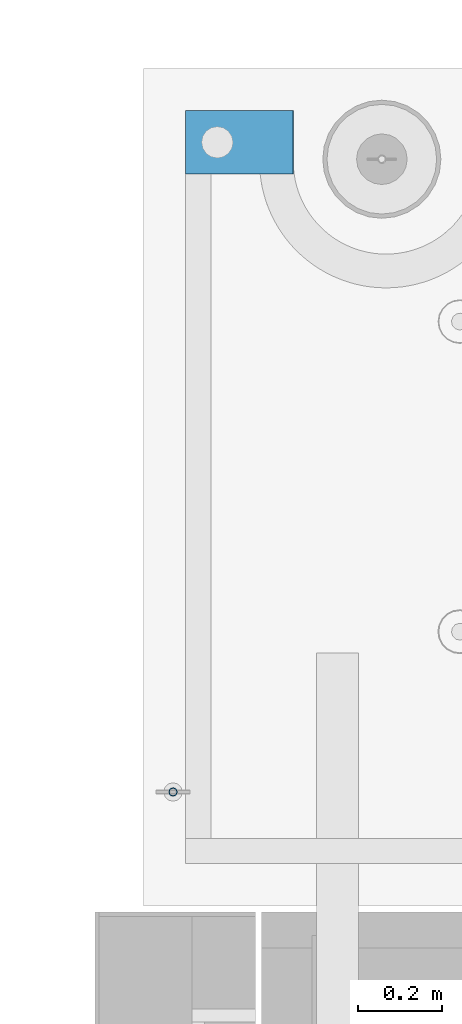
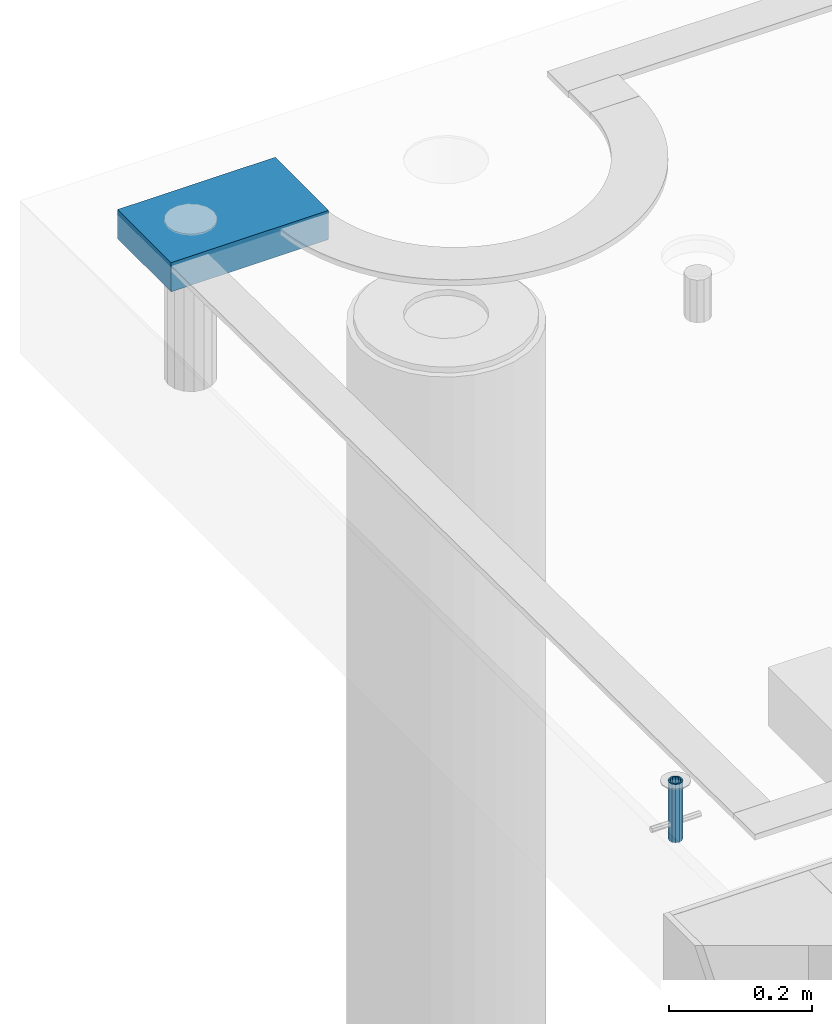
# One storey, part 154 of 349: 2 beams, 2 elements without a shape of their own.
"""IFC2X3 building model written with IfcOpenShell, lengths in millimetres."""

from ifc_helpers import new_model, si_unit, frame, origin_with_axes, place, context, subcontext, project, spatial, faceted_brep, material, type_object, element, aggregate, save


model = new_model("IFC2X3")

# Units and contexts
model_context = context("Model", 3, precision=1e-05, world=origin_with_axes())
body_context = subcontext(model_context, "Body", "Model", "MODEL_VIEW")
ifc_project = project(units=[si_unit("LENGTHUNIT", "METRE", prefix="MILLI"), si_unit("AREAUNIT", "SQUARE_METRE"), si_unit("VOLUMEUNIT", "CUBIC_METRE"), si_unit("MASSUNIT", "GRAM", prefix="KILO"), si_unit("TIMEUNIT", "SECOND"), si_unit("PLANEANGLEUNIT", "RADIAN"), si_unit("SOLIDANGLEUNIT", "STERADIAN"), si_unit("THERMODYNAMICTEMPERATUREUNIT", "DEGREE_CELSIUS"), si_unit("LUMINOUSINTENSITYUNIT", "LUMEN")], contexts=[model_context])

# Site, building, storey
site_placement = place(None, origin_with_axes())
site = spatial("IfcSite", under=ifc_project, at=site_placement, CompositionType="ELEMENT")
building_placement = place(site_placement, origin_with_axes())
building = spatial("IfcBuilding", under=site, at=building_placement, CompositionType="ELEMENT")
storey_placement = place(building_placement, origin_with_axes())
storey = spatial("IfcBuildingStorey", under=building, at=storey_placement, Name="4", CompositionType="ELEMENT", Elevation=0.0)

# Assemblies, beams
assembly_1_placement = place(storey_placement, origin_with_axes())
assembly_1 = element("IfcElementAssembly", 1, at=assembly_1_placement, inside=storey, AssemblyPlace="NOTDEFINED", PredefinedType="REINFORCEMENT_UNIT")
ifc_material_1 = material(Name="CONCRETE/Concrete_Undefined")
beam_type_1 = type_object("IfcBeamType", PredefinedType="NOTDEFINED")
beam_1_placement = place(assembly_1_placement, frame((7834.97852488622, 22709.9981419457, 93691.8130006467), z_axis=(-0.000811736999627788, 6.99999872856177e-09, 0.999999670541467), x_axis=(0.99999967050638, -8.37699998998561e-06, 0.000811736999618736)))
beam_1 = element("IfcBeam", 2, at=beam_1_placement, type_object=beam_type_1, material=ifc_material_1, context=body_context, shape_type="Brep", body=[
    faceted_brep([(0.0, 75.0, -25.0), (1.81898940354586e-12, 75.0, 25.0), (254.995831308013, 74.9999999999964, 24.9999999999709), (254.995831308012, 74.9999999999964, -25.0000000000146), (1.81898940354586e-12, -75.0000000000009, 25.0), (254.995831308014, -75.0000000000036, 24.9999999999854), (0.0, -75.0, -25.0), (254.995831308011, -75.0000000000036, -25.0000000000146)], [[[0, 1, 2, 3]], [[1, 4, 5, 2]], [[4, 6, 7, 5]], [[6, 0, 3, 7]], [[5, 7, 3, 2]], [[6, 4, 1, 0]]]),
])
assembly_2_placement = place(assembly_1_placement, origin_with_axes())
assembly_2 = element("IfcElementAssembly", 3, at=assembly_2_placement, Name="Steel Assembly", AssemblyPlace="NOTDEFINED", PredefinedType="RIGID_FRAME")
aggregate(assembly_1, [assembly_2, beam_1])
ifc_material_2 = material(Name="STEEL/1.4301")
beam_type_2 = type_object("IfcBeamType", PredefinedType="NOTDEFINED")
beam_2_placement = place(assembly_2_placement, frame((7804.99906039055, 21170.0168887753, 93730.9999983246), z_axis=(-1.43919999976435e-05, -0.999999999896435, 0.0), x_axis=(0.0, 0.0, -1.0)))
beam_2 = element("IfcBeam", 4, at=beam_2_placement, type_object=beam_type_2, material=ifc_material_2, context=body_context, shape_type="Brep", body=[
    faceted_brep([(0.0, -8.0, 0.0), (0.0, -6.92820323027263, 4.0), (100.000000000029, -6.92820323027263, 4.0), (100.000000000029, -7.99999999999636, 0.0), (0.0, -4.0, 6.92820323027627), (100.000000000029, -4.0, 6.92820323027536), (0.0, 0.0, 8.0), (100.000000000029, 3.63797880709171e-12, 8.0), (0.0, 4.0, 6.92820323027627), (100.000000000029, 4.0, 6.92820323027536), (0.0, 6.92820323027263, 4.0), (100.000000000029, 6.92820323027627, 3.99999999999909), (0.0, 8.0, 0.0), (100.000000000029, 8.0, 0.0), (0.0, 6.92820323027263, -4.0), (100.000000000029, 6.92820323027627, -4.00000000000091), (0.0, 4.0, -6.92820323027627), (100.000000000029, 4.00000000000364, -6.92820323027536), (0.0, 0.0, -8.0), (100.000000000029, 3.63797880709171e-12, -8.00000000000091), (0.0, -4.0, -6.92820323027627), (100.000000000029, -3.99999999999636, -6.92820323027627), (0.0, -6.92820323027263, -4.0), (100.000000000029, -6.92820323027263, -4.0), (0.0, -10.4999999999927, -1.45519152283669e-11), (0.0, -9.09326673972828, -5.25000000001455), (100.000000000262, -9.09326673972828, -5.25000000001455), (100.000000000262, -10.4999999999927, -1.45519152283669e-11), (0.0, -5.24999999998545, -9.09326673974283), (100.000000000262, -5.24999999998545, -9.09326673974283), (0.0, 7.27595761418343e-12, -10.5), (100.000000000262, 7.27595761418343e-12, -10.5), (0.0, 5.25000000001455, -9.09326673975738), (100.000000000262, 5.25000000001455, -9.09326673975738), (0.0, 9.09326673975011, -5.25000000001455), (100.000000000262, 9.09326673975011, -5.25000000001455), (0.0, 10.5000000000073, -1.45519152283669e-11), (100.000000000262, 10.5000000000073, -1.45519152283669e-11), (0.0, 9.09326673975011, 5.25), (100.000000000262, 9.09326673975011, 5.25), (0.0, 5.25000000000728, 9.09326673972828), (100.000000000262, 5.25000000000728, 9.09326673972828), (0.0, 1.45519152283669e-11, 10.4999999999854), (100.000000000262, 1.45519152283669e-11, 10.4999999999854), (0.0, -5.24999999999272, 9.09326673972828), (100.000000000262, -5.24999999999272, 9.09326673972828), (0.0, -9.09326673972828, 5.24999999998545), (100.000000000262, -9.09326673972828, 5.24999999998545)], [[[0, 1, 2, 3]], [[1, 4, 5, 2]], [[4, 6, 7, 5]], [[6, 8, 9, 7]], [[8, 10, 11, 9]], [[10, 12, 13, 11]], [[12, 14, 15, 13]], [[14, 16, 17, 15]], [[16, 18, 19, 17]], [[18, 20, 21, 19]], [[20, 22, 23, 21]], [[22, 0, 3, 23]], [[24, 25, 26, 27]], [[25, 28, 29, 26]], [[28, 30, 31, 29]], [[30, 32, 33, 31]], [[32, 34, 35, 33]], [[34, 36, 37, 35]], [[36, 38, 39, 37]], [[38, 40, 41, 39]], [[40, 42, 43, 41]], [[42, 44, 45, 43]], [[44, 46, 47, 45]], [[46, 24, 27, 47]], [[29, 31, 33, 35, 37, 39, 41, 43, 45, 47, 27, 26], [5, 7, 9, 11, 13, 15, 17, 19, 21, 23, 3, 2]], [[46, 44, 42, 40, 38, 36, 34, 32, 30, 28, 25, 24], [22, 20, 18, 16, 14, 12, 10, 8, 6, 4, 1, 0]]]),
])
aggregate(assembly_2, [beam_2])

save(model, "model.ifc")
